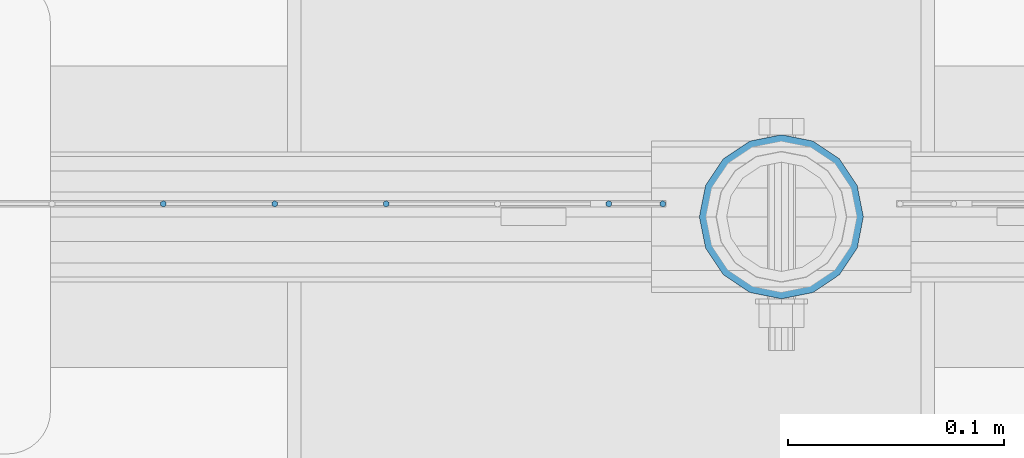
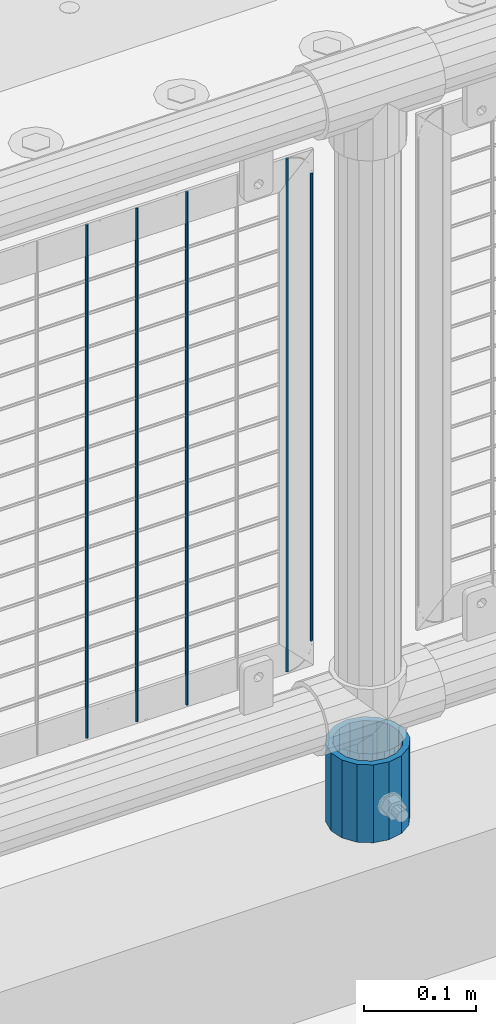
# One storey, part 71 of 240: 6 columns.
"""IFC2X3 building model written with IfcOpenShell, lengths in millimetres."""

from ifc_helpers import new_model, si_unit, frame, origin_with_axes, place, context, subcontext, project, spatial, faceted_brep, material, type_object, element, save


model = new_model("IFC2X3")

# Units and contexts
model_context = context("Model", 3, precision=1e-05, world=origin_with_axes())
body_context = subcontext(model_context, "Body", "Model", "MODEL_VIEW")
ifc_project = project(units=[si_unit("LENGTHUNIT", "METRE", prefix="MILLI"), si_unit("AREAUNIT", "SQUARE_METRE"), si_unit("VOLUMEUNIT", "CUBIC_METRE"), si_unit("MASSUNIT", "GRAM", prefix="KILO"), si_unit("TIMEUNIT", "SECOND"), si_unit("PLANEANGLEUNIT", "RADIAN"), si_unit("SOLIDANGLEUNIT", "STERADIAN"), si_unit("THERMODYNAMICTEMPERATUREUNIT", "DEGREE_CELSIUS"), si_unit("LUMINOUSINTENSITYUNIT", "LUMEN")], contexts=[model_context])

# Site, building, storey
site_placement = place(None, origin_with_axes())
site = spatial("IfcSite", under=ifc_project, at=site_placement, CompositionType="ELEMENT")
building_placement = place(site_placement, origin_with_axes())
building = spatial("IfcBuilding", under=site, at=building_placement, Name="Standard", CompositionType="ELEMENT")
storey_placement = place(building_placement, origin_with_axes())
storey = spatial("IfcBuildingStorey", under=building, at=storey_placement, Name="Undefined", CompositionType="ELEMENT", Elevation=0.0)

# Columns
ifc_material_1 = material(Name="Misc_Undefined")
column_type_1 = type_object("IfcColumnType", Name="D3", PredefinedType="NOTDEFINED")
for number, where, z_axis, x_axis in (
    (1, (44545.685, 34670.5, 353.02), (-1.0, 0.0, 0.0), (0.0, 0.0, 1.0)),
    (2, (44494.03, 34670.5, 353.02), (-1.0, 0.0, 0.0), (0.0, 0.0, 1.0)),
    (3, (44442.375, 34670.5, 353.02), (-1.0, 0.0, 0.0), (0.0, 0.0, 1.0)),
    (4, (44648.995, 34670.5, 353.02), (-1.0, 0.0, 0.0), (0.0, 0.0, 1.0)),
):
    element("IfcColumn", number, at=place(storey_placement, frame(where, z_axis=z_axis, x_axis=x_axis)), inside=storey, type_object=column_type_1, material=ifc_material_1, ObjectType="D3", context=body_context, shape_type="Brep", body=[
        faceted_brep([(-7.27595761418343e-12, -1.49999999999272, 0.0), (-7.27595761418343e-12, -0.749999999992724, -1.29903810567669), (560.0, -0.75, -1.29903810567339), (560.0, -1.5, 0.0), (0.0, 0.750000000007276, -1.29903810567669), (560.0, 0.75, -1.29903810567339), (0.0, 1.50000000000728, 0.0), (560.0, 1.5, 0.0), (0.0, 0.750000000007276, 1.29903810567669), (560.0, 0.75, 1.29903810567339), (-7.27595761418343e-12, -0.749999999992724, 1.29903810567669), (560.0, -0.75, 1.29903810567339)], [[[0, 1, 2, 3]], [[1, 4, 5, 2]], [[4, 6, 7, 5]], [[6, 8, 9, 7]], [[8, 10, 11, 9]], [[10, 0, 3, 11]], [[5, 7, 9, 11, 3, 2]], [[10, 8, 6, 4, 1, 0]]]),
    ])
column_1_placement = place(storey_placement, frame((44674.0, 34670.5, 378.02), z_axis=(-1.0, 0.0, 0.0), x_axis=(0.0, 0.0, 1.0)))
element("IfcColumn", 5, at=column_1_placement, inside=storey, type_object=column_type_1, material=ifc_material_1, ObjectType="D3", context=body_context, shape_type="Brep", body=[
    faceted_brep([(-7.27595761418343e-12, -1.49999999999272, 0.0), (-7.27595761418343e-12, -0.749999999992724, -1.29903810567669), (510.0, -0.75, -1.29903810567339), (510.0, -1.5, 0.0), (0.0, 0.750000000007276, -1.29903810567669), (510.0, 0.75, -1.29903810567339), (0.0, 1.50000000000728, 0.0), (510.0, 1.5, 0.0), (0.0, 0.750000000007276, 1.29903810567669), (510.0, 0.75, 1.29903810567339), (-7.27595761418343e-12, -0.749999999992724, 1.29903810567669), (510.0, -0.75, 1.29903810567339)], [[[0, 1, 2, 3]], [[1, 4, 5, 2]], [[4, 6, 7, 5]], [[6, 8, 9, 7]], [[8, 10, 11, 9]], [[10, 0, 3, 11]], [[5, 7, 9, 11, 3, 2]], [[10, 8, 6, 4, 1, 0]]]),
])
ifc_material_2 = material()
column_type_2 = type_object("IfcColumnType", PredefinedType="NOTDEFINED")
column_2_placement = place(storey_placement, frame((44729.0, 34664.5, 168.02), z_axis=(0.0, 1.0, 0.0), x_axis=(0.0, 0.0, 1.0)))
element("IfcColumn", 6, at=column_2_placement, inside=storey, type_object=column_type_2, material=ifc_material_2, context=body_context, shape_type="Brep", body=[
    faceted_brep([(0.0, -31.75, 0.0), (0.0, -29.3331751572332, 12.1501989775934), (85.0, -29.3331751572332, 12.1501989775934), (85.0, -31.75, 0.0), (0.0, -22.4506403026753, 22.4506403026753), (85.0, -22.4506403026753, 22.4506403026753), (0.0, -12.1501989775934, 29.3331751572332), (85.0, -12.1501989775934, 29.3331751572332), (0.0, 0.0, 31.75), (85.0, 0.0, 31.75), (0.0, 12.1501989775934, 29.3331751572332), (85.0, 12.1501989775934, 29.3331751572332), (0.0, 22.4506403026753, 22.4506403026753), (85.0, 22.4506403026753, 22.4506403026753), (0.0, 29.3331751572332, 12.1501989775934), (85.0, 29.3331751572332, 12.1501989775934), (0.0, 31.75, 0.0), (85.0, 31.75, 0.0), (0.0, 29.3331751572332, -12.1501989775934), (85.0, 29.3331751572332, -12.1501989775934), (0.0, 22.4506403026753, -22.4506403026753), (85.0, 22.4506403026753, -22.4506403026753), (0.0, 12.1501989775934, -29.3331751572332), (85.0, 12.1501989775934, -29.3331751572332), (0.0, 0.0, -31.75), (85.0, 0.0, -31.75), (0.0, -12.1501989775934, -29.3331751572332), (85.0, -12.1501989775934, -29.3331751572332), (0.0, -22.4506403026753, -22.4506403026753), (85.0, -22.4506403026753, -22.4506403026753), (0.0, -29.3331751572332, -12.1501989775934), (85.0, -29.3331751572332, -12.1501989775934), (0.0, -38.0500000000029, 0.0), (0.0, -35.1536162120537, -14.5611046014892), (85.0, -35.1536162120537, -14.5611046014892), (85.0, -38.0500000000029, 0.0), (0.0, -26.9054130241493, -26.9054130241493), (85.0, -26.9054130241493, -26.9054130241493), (0.0, -14.5611046014892, -35.1536162120537), (85.0, -14.5611046014892, -35.1536162120537), (0.0, 0.0, -38.0500000000029), (85.0, 0.0, -38.0500000000029), (0.0, 14.5611046014892, -35.1536162120537), (85.0, 14.5611046014892, -35.1536162120537), (0.0, 26.9054130241493, -26.9054130241493), (85.0, 26.9054130241493, -26.9054130241493), (0.0, 35.1536162120537, -14.5611046014892), (85.0, 35.1536162120537, -14.5611046014892), (0.0, 38.0500000000029, 0.0), (85.0, 38.0500000000029, 0.0), (0.0, 35.1536162120537, 14.5611046014892), (85.0, 35.1536162120537, 14.5611046014892), (0.0, 26.9054130241493, 26.9054130241493), (85.0, 26.9054130241493, 26.9054130241493), (0.0, 14.5611046014892, 35.1536162120537), (85.0, 14.5611046014892, 35.1536162120537), (0.0, 0.0, 38.0500000000029), (85.0, 0.0, 38.0500000000029), (0.0, -14.5611046014892, 35.1536162120537), (85.0, -14.5611046014892, 35.1536162120537), (0.0, -26.9054130241493, 26.9054130241493), (85.0, -26.9054130241493, 26.9054130241493), (0.0, -35.1536162120537, 14.5611046014892), (85.0, -35.1536162120537, 14.5611046014892)], [[[0, 1, 2, 3]], [[1, 4, 5, 2]], [[4, 6, 7, 5]], [[6, 8, 9, 7]], [[8, 10, 11, 9]], [[10, 12, 13, 11]], [[12, 14, 15, 13]], [[14, 16, 17, 15]], [[16, 18, 19, 17]], [[18, 20, 21, 19]], [[20, 22, 23, 21]], [[22, 24, 25, 23]], [[24, 26, 27, 25]], [[26, 28, 29, 27]], [[28, 30, 31, 29]], [[30, 0, 3, 31]], [[32, 33, 34, 35]], [[33, 36, 37, 34]], [[36, 38, 39, 37]], [[38, 40, 41, 39]], [[40, 42, 43, 41]], [[42, 44, 45, 43]], [[44, 46, 47, 45]], [[46, 48, 49, 47]], [[48, 50, 51, 49]], [[50, 52, 53, 51]], [[52, 54, 55, 53]], [[54, 56, 57, 55]], [[56, 58, 59, 57]], [[58, 60, 61, 59]], [[60, 62, 63, 61]], [[62, 32, 35, 63]], [[37, 39, 41, 43, 45, 47, 49, 51, 53, 55, 57, 59, 61, 63, 35, 34], [5, 7, 9, 11, 13, 15, 17, 19, 21, 23, 25, 27, 29, 31, 3, 2]], [[62, 60, 58, 56, 54, 52, 50, 48, 46, 44, 42, 40, 38, 36, 33, 32], [30, 28, 26, 24, 22, 20, 18, 16, 14, 12, 10, 8, 6, 4, 1, 0]]]),
])

save(model, "model.ifc")
